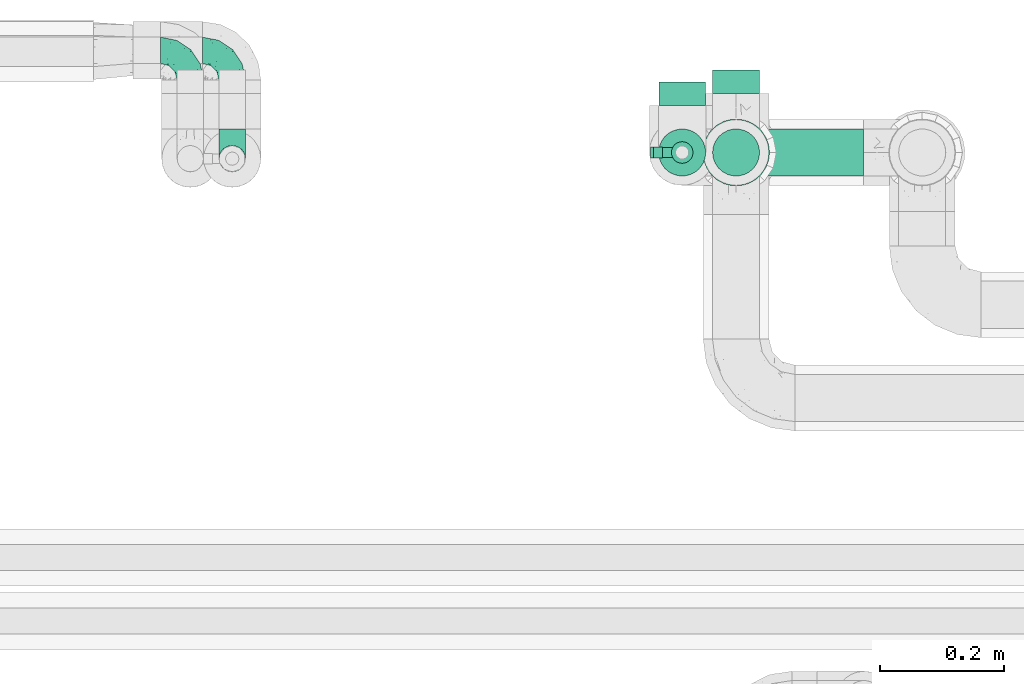
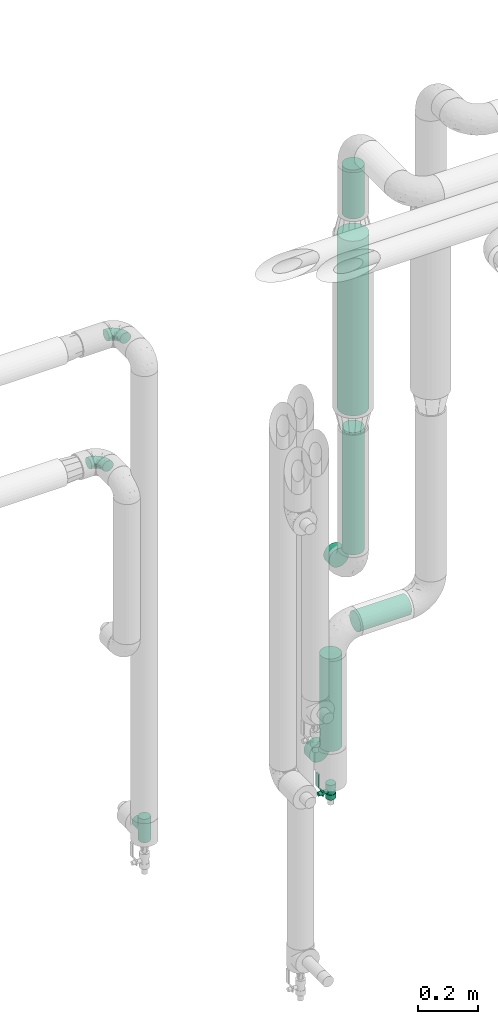
# One storey, part 641 of 827: 5 flow fittings, 5 flow segments, 1 flow controller.
"""IFC2X3 building model written with IfcOpenShell, lengths in millimetres."""

from ifc_helpers import new_model, entity, si_unit, converted_unit, derived_unit, direction, frame, origin, origin_2d_with_axis, place, context, subcontext, project, spatial, polyline, circle, outline, extrude, faceted_brep, source, transform, mapped, material, material_list, type_object, type_shapes, element, save


model = new_model("IFC2X3")

# Units and contexts
model_context = context("Model", 3, precision=0.01, world=origin(), true_north=direction((6.12303176911189e-17, 1.0)))
body_context = subcontext(model_context, "Body", "Model", "MODEL_VIEW")
ifc_project = project(units=[si_unit("LENGTHUNIT", "METRE", prefix="MILLI"), si_unit("AREAUNIT", "SQUARE_METRE"), si_unit("VOLUMEUNIT", "CUBIC_METRE"), converted_unit("PLANEANGLEUNIT", "DEGREE", entity("IfcRatioMeasure", 0.0174532925199433), si_unit("PLANEANGLEUNIT", "RADIAN"), dimensions=[0, 0, 0, 0, 0, 0, 0]), si_unit("MASSUNIT", "GRAM", prefix="KILO"), derived_unit("MASSDENSITYUNIT", [(si_unit("MASSUNIT", "GRAM", prefix="KILO"), 1), (si_unit("LENGTHUNIT", "METRE"), -3)]), derived_unit("MOMENTOFINERTIAUNIT", [(si_unit("LENGTHUNIT", "METRE"), 4)]), si_unit("TIMEUNIT", "SECOND"), si_unit("FREQUENCYUNIT", "HERTZ"), si_unit("THERMODYNAMICTEMPERATUREUNIT", "DEGREE_CELSIUS"), derived_unit("THERMALTRANSMITTANCEUNIT", [(si_unit("MASSUNIT", "GRAM", prefix="KILO"), 1), (si_unit("THERMODYNAMICTEMPERATUREUNIT", "KELVIN"), -1), (si_unit("TIMEUNIT", "SECOND"), -3)]), derived_unit("VOLUMETRICFLOWRATEUNIT", [(si_unit("LENGTHUNIT", "METRE"), 3), (si_unit("TIMEUNIT", "SECOND"), -1)]), derived_unit("MASSFLOWRATEUNIT", [(si_unit("MASSUNIT", "GRAM", prefix="KILO"), 1), (si_unit("TIMEUNIT", "SECOND"), -1)]), derived_unit("ROTATIONALFREQUENCYUNIT", [(si_unit("TIMEUNIT", "SECOND"), -1)]), si_unit("ELECTRICCURRENTUNIT", "AMPERE"), si_unit("ELECTRICVOLTAGEUNIT", "VOLT"), si_unit("POWERUNIT", "WATT"), si_unit("FORCEUNIT", "NEWTON", prefix="KILO"), si_unit("ILLUMINANCEUNIT", "LUX"), si_unit("LUMINOUSFLUXUNIT", "LUMEN"), si_unit("LUMINOUSINTENSITYUNIT", "CANDELA"), derived_unit("USERDEFINED", [(si_unit("MASSUNIT", "GRAM", prefix="KILO"), -1), (si_unit("LENGTHUNIT", "METRE"), -2), (si_unit("TIMEUNIT", "SECOND"), 3), (si_unit("LUMINOUSFLUXUNIT", "LUMEN"), 1)]), derived_unit("LINEARVELOCITYUNIT", [(si_unit("LENGTHUNIT", "METRE"), 1), (si_unit("TIMEUNIT", "SECOND"), -1)]), si_unit("PRESSUREUNIT", "PASCAL"), derived_unit("USERDEFINED", [(si_unit("LENGTHUNIT", "METRE"), -2), (si_unit("MASSUNIT", "GRAM", prefix="KILO"), 1), (si_unit("TIMEUNIT", "SECOND"), -2)]), derived_unit("LINEARFORCEUNIT", [(si_unit("MASSUNIT", "GRAM", prefix="KILO"), 1), (si_unit("LENGTHUNIT", "METRE"), 1), (si_unit("TIMEUNIT", "SECOND"), -2), (si_unit("LENGTHUNIT", "METRE"), -1)]), derived_unit("PLANARFORCEUNIT", [(si_unit("MASSUNIT", "GRAM", prefix="KILO"), 1), (si_unit("LENGTHUNIT", "METRE"), 1), (si_unit("TIMEUNIT", "SECOND"), -2), (si_unit("LENGTHUNIT", "METRE"), -2)])], contexts=[model_context])

# Site, building, storey
site_placement = place(None, origin())
site = spatial("IfcSite", under=ifc_project, at=site_placement, CompositionType="ELEMENT")
building_placement = place(site_placement, origin())
building = spatial("IfcBuilding", under=site, at=building_placement, CompositionType="ELEMENT")
storey_placement = place(building_placement, frame((0.0, 0.0, 28200.0)))
storey = spatial("IfcBuildingStorey", under=building, at=storey_placement, Name="08", CompositionType="ELEMENT", Elevation=28200.0)

# Flow segments
pipe_segment_type = type_object("IfcPipeSegmentType", PredefinedType="NOTDEFINED")
flow_segment_1_placement = place(storey_placement, frame((31328.81, 19313.84, 451.0)))
element("IfcFlowSegment", 1, at=flow_segment_1_placement, inside=storey, type_object=pipe_segment_type, context=body_context, shape_type="SweptSolid", body=[
    extrude(circle(Radius=38.0, at=origin_2d_with_axis()), frame((39.6, 39.6, 0.0), z_axis=(0.0, 0.0, 1.0), x_axis=(-1.0, 0.0, 0.0)), (0.0, 0.0, 1.0), 379.261639999987),
])
flow_segment_2_placement = place(storey_placement, frame((31463.41, 19313.84, 885.67)))
element("IfcFlowSegment", 2, at=flow_segment_2_placement, inside=storey, type_object=pipe_segment_type, context=body_context, shape_type="SweptSolid", body=[
    extrude(circle(Radius=38.0, at=origin_2d_with_axis()), frame((0.0, 39.6, 39.6), z_axis=(1.0, 0.0, 0.0), x_axis=(0.0, -1.0, 0.0)), (0.0, 0.0, 1.0), 197.500000000011),
])
flow_segment_3_placement = place(storey_placement, frame((31399.81, 19297.84, 1805.45)))
element("IfcFlowSegment", 3, at=flow_segment_3_placement, inside=storey, type_object=pipe_segment_type, context=body_context, shape_type="SweptSolid", body=[
    extrude(circle(Radius=54.0, at=origin_2d_with_axis()), frame((55.6, 55.6, 0.0)), (0.0, 0.0, 1.0), 714.55174000002),
])
flow_segment_4_placement = place(storey_placement, frame((31415.81, 19313.84, 1225.45)))
element("IfcFlowSegment", 4, at=flow_segment_4_placement, inside=storey, type_object=pipe_segment_type, context=body_context, shape_type="SweptSolid", body=[
    extrude(circle(Radius=38.0, at=origin_2d_with_axis()), frame((39.6, 39.6, 0.0), z_axis=(0.0, 0.0, 1.0), x_axis=(-1.0, 0.0, 0.0)), (0.0, 0.0, 1.0), 500.000000000008),
])
flow_segment_5_placement = place(storey_placement, frame((31415.81, 19313.84, 2600.0)))
element("IfcFlowSegment", 5, at=flow_segment_5_placement, inside=storey, type_object=pipe_segment_type, context=body_context, shape_type="SweptSolid", body=[
    extrude(circle(Radius=38.0, at=origin_2d_with_axis()), frame((39.6, 39.6, 0.0), z_axis=(0.0, 0.0, 1.0), x_axis=(-1.0, 0.0, 0.0)), (0.0, 0.0, 1.0), 200.080617222013),
])

# Flow controller
ifc_material = material()
ifc_material_list = material_list([ifc_material, ifc_material, ifc_material, ifc_material, ifc_material])
valve_type = type_object("IfcValveType", PredefinedType="NOTDEFINED", material=ifc_material_list)
shared_shape_1 = source(origin(), body_context, "Body", "SweptSolid", [
    extrude(circle(Radius=17.5, at=origin_2d_with_axis()), frame((-30.5, 0.0, 0.0), z_axis=(1.0, 0.0, 0.0), x_axis=(0.0, 1.0, 0.0)), (0.0, 0.0, 1.0), 20.3333333333333),
    extrude(circle(Radius=16.0, at=origin_2d_with_axis()), frame((-10.17, 0.0, 0.0), z_axis=(1.0, 0.0, 0.0), x_axis=(0.0, 1.0, 0.0)), (0.0, 0.0, 1.0), 20.3333333333333),
    extrude(circle(Radius=17.5, at=origin_2d_with_axis()), frame((10.17, 0.0, 0.0), z_axis=(1.0, 0.0, 0.0), x_axis=(0.0, 1.0, 0.0)), (0.0, 0.0, 1.0), 20.3333333333333),
    extrude(outline(polyline([(-38.75, -5.0), (-38.75, -10.0), (-17.92, -10.0), (2.08, 5.0), (56.25, 5.0), (56.25, 10.0), (0.42, 10.0), (-19.58, -5.0), (-38.75, -5.0)])), frame((28.75, -8.75, 41.5), z_axis=(0.0, -1.0, 0.0), x_axis=(1.0, 0.0, 0.0)), (0.0, 0.0, -1.0), 17.5),
    extrude(circle(Radius=8.0, at=origin_2d_with_axis()), origin(), (0.0, 0.0, 1.0), 49.0),
])
type_shapes(valve_type, [shared_shape_1])
flow_controller_placement = place(storey_placement, frame((31368.41, 19353.43, 268.5), z_axis=(-1.0, 0.0, 0.0), x_axis=(0.0, 0.0, 1.0)))
element("IfcFlowController", 6, at=flow_controller_placement, inside=storey, type_object=valve_type, material=ifc_material, context=body_context, shape_type="MappedRepresentation", body=[
    mapped(shared_shape_1, transform((0.0, 0.0, 0.0), scale=1.0)),
])

# Flow fittings
pipe_fitting_type_1 = type_object("IfcPipeFittingType", Name="ADSK_1", PredefinedType="NOTDEFINED", material=ifc_material)
shared_shape_2 = source(origin(), body_context, "Body", "SweptSolid", [
    extrude(circle(Radius=38.05, at=origin_2d_with_axis()), frame((0.0, 0.0, 0.0), z_axis=(1.0, 0.0, 0.0), x_axis=(0.0, 1.0, 0.0)), (0.0, 0.0, 1.0), 38.0000000000003),
])
type_shapes(pipe_fitting_type_1, [shared_shape_2])
for number, where, z_axis, x_axis, name in (
    (7, (31455.41, 19448.43, 1130.45), (1.0, 0.0, 0.0), (0.0, 1.0, 0.0), "ADSK_1"),
    (8, (31368.41, 19429.43, 375.0), (-1.0, 0.0, 0.0), (0.0, 1.0, 0.0), "ADSK_1"),
):
    element("IfcFlowFitting", number, at=place(storey_placement, frame(where, z_axis=z_axis, x_axis=x_axis)), inside=storey, type_object=pipe_fitting_type_1, material=ifc_material, Name=name, ObjectType="ADSK_1", context=body_context, shape_type="MappedRepresentation", body=[
        mapped(shared_shape_2, transform((0.0, 0.0, 0.0), scale=1.0)),
    ])
pipe_fitting_type_2 = type_object("IfcPipeFittingType", Name="ADSK_1", PredefinedType="NOTDEFINED", material=ifc_material)
shared_shape_3 = source(origin(), body_context, "Body", "Brep", [
    faceted_brep([(-48.0, 10.6, -18.36), (-48.0, 5.49, -20.48), (-48.0, 0.0, -21.2), (-48.0, -5.49, -20.48), (-48.0, -10.6, -18.36), (-48.0, -14.99, -14.99), (-48.0, -18.36, -10.6), (-48.0, -20.48, -5.49), (-48.0, -21.2, 0.0), (-48.0, -20.48, 5.49), (-48.0, -18.36, 10.6), (-48.0, -14.99, 14.99), (-48.0, -10.6, 18.36), (-48.0, -5.49, 20.48), (-48.0, 0.0, 21.2), (-48.0, 5.49, 20.48), (-48.0, 10.6, 18.36), (-48.0, 14.99, 14.99), (-48.0, 18.36, 10.6), (-48.0, 20.48, 5.49), (-48.0, 21.2, 0.0), (-48.0, 20.48, -5.49), (-48.0, 18.36, -10.6), (-48.0, 14.99, -14.99), (0.0, 48.0, -21.2), (-5.49, 48.0, -20.48), (-10.6, 48.0, -18.36), (-14.99, 48.0, -14.99), (-18.36, 48.0, -10.6), (-20.48, 48.0, -5.49), (-21.2, 48.0, 0.0), (-20.48, 48.0, 5.49), (-18.36, 48.0, 10.6), (-14.99, 48.0, 14.99), (-10.6, 48.0, 18.36), (-5.49, 48.0, 20.48), (0.0, 48.0, 21.2), (5.49, 48.0, 20.48), (10.6, 48.0, 18.36), (14.99, 48.0, 14.99), (18.36, 48.0, 10.6), (20.48, 48.0, 5.49), (21.2, 48.0, 0.0), (20.48, 48.0, -5.49), (18.36, 48.0, -10.6), (14.99, 48.0, -14.99), (10.6, 48.0, -18.36), (5.49, 48.0, -20.48), (-35.25, -16.22, 12.01), (-34.76, -18.57, 0.0), (-20.87, -12.37, 10.9), (-31.49, -11.78, 15.9), (-37.0, -2.58, 20.86), (-33.89, 3.62, 21.15), (-31.81, -18.14, 6.76), (-5.78, 5.78, 17.67), (-19.42, -4.1, 17.86), (-9.6, -3.39, 13.73), (-35.44, -7.73, 19.13), (11.78, 31.49, 15.9), (-5.93, -5.46, 6.95), (-18.45, -13.78, 5.46), (-10.29, -8.43, 0.0), (-24.6, 0.55, 20.62), (-37.28, 17.94, 13.81), (-33.38, 22.85, 9.59), (-41.46, 20.06, 8.75), (-29.51, 20.45, 15.16), (-15.04, 10.79, 21.13), (-7.08, 16.98, 20.93), (-8.39, 23.51, 21.15), (-40.86, 13.03, 17.26), (-8.05, 41.26, 19.83), (-3.21, 35.97, 21.14), (8.53, 19.66, 14.74), (4.1, 19.42, 17.86), (-37.72, 22.66, 4.78), (-37.07, 8.58, 19.98), (-13.0, 5.43, 19.97), (-3.78, 13.93, 19.7), (3.02, 8.69, 13.43), (-2.27, -0.05, 10.65), (6.22, 6.99, 7.09), (-22.25, 34.6, 9.45), (18.14, 31.81, 6.76), (16.22, 35.25, 12.01), (12.37, 20.87, 10.9), (7.73, 35.44, 19.13), (-21.52, -15.93, 0.0), (2.58, 37.0, 20.86), (18.57, 34.76, 0.0), (13.78, 18.45, 5.46), (15.93, 21.52, 0.0), (-20.03, -8.54, 14.9), (-28.6, 28.6, 5.16), (-24.79, 34.6, 0.0), (-34.6, 24.79, 0.0), (-22.81, 37.41, 4.68), (-23.36, 26.33, 14.79), (-13.68, 37.05, 17.49), (-17.72, 38.12, 13.73), (-26.25, 27.3, 11.24), (-9.71, 32.34, 20.14), (-17.26, 25.6, 18.71), (-26.33, 9.99, 20.77), (-24.06, 6.05, 21.2), (-25.02, 15.46, 19.56), (-24.3, 20.72, 17.57), (-31.95, 15.23, 17.8), (-13.53, 24.7, 20.21), (-17.6, 17.6, 20.6), (-0.55, 24.6, 20.62), (-11.41, -7.48, 10.43), (0.93, -0.93, 0.0), (8.43, 10.29, 0.0), (-11.41, -7.48, -10.43), (-20.1, -8.84, -14.66), (-9.6, -3.39, -13.73), (7.73, 35.44, -19.13), (4.1, 19.42, -17.86), (-0.55, 24.6, -20.62), (-38.12, 17.72, -13.73), (-37.05, 13.68, -17.49), (-32.34, 9.71, -20.14), (-41.26, 8.05, -19.83), (-37.41, 22.81, -4.68), (-23.51, 8.39, -21.15), (-35.97, 3.21, -21.14), (-28.6, 28.6, -5.16), (-31.81, -18.14, -6.76), (-18.45, -13.78, -5.46), (-25.6, 17.26, -18.71), (-19.42, -4.1, -17.86), (-17.94, 37.28, -13.81), (-22.85, 33.38, -9.59), (-20.06, 41.46, -8.75), (-31.49, -11.78, -15.9), (-35.25, -16.22, -12.01), (8.53, 19.66, -14.74), (11.78, 31.49, -15.9), (-9.99, 26.33, -20.77), (-6.05, 24.06, -21.2), (-10.79, 15.04, -21.13), (-37.0, -2.58, -20.86), (-16.98, 7.08, -20.93), (-5.43, 13.0, -19.97), (-13.93, 3.78, -19.7), (-20.87, -12.37, -10.9), (-26.33, 23.36, -14.79), (-22.66, 37.72, -4.78), (13.78, 18.45, -5.46), (18.14, 31.81, -6.76), (-15.46, 25.02, -19.56), (-20.72, 24.3, -17.57), (16.22, 35.25, -12.01), (-13.03, 40.86, -17.26), (-8.58, 37.07, -19.98), (2.58, 37.0, -20.86), (-3.62, 33.89, -21.15), (-34.6, 22.25, -9.45), (6.22, 6.99, -7.09), (-20.45, 29.51, -15.16), (-35.44, -7.73, -19.13), (12.37, 20.87, -10.9), (-27.3, 26.25, -11.24), (-15.23, 31.95, -17.8), (-24.7, 13.53, -20.21), (-24.6, 0.55, -20.62), (-5.78, 5.78, -17.67), (-17.6, 17.6, -20.6), (3.02, 8.69, -13.43), (-5.93, -5.46, -6.95), (-2.27, -0.05, -10.65)], [[[0, 1, 2, 3, 4, 5, 6, 7, 8, 9, 10, 11, 12, 13, 14, 15, 16, 17, 18, 19, 20, 21, 22, 23]], [[24, 25, 26, 27, 28, 29, 30, 31, 32, 33, 34, 35, 36, 37, 38, 39, 40, 41, 42, 43, 44, 45, 46, 47]], [[10, 48, 11]], [[9, 8, 49]], [[48, 50, 51]], [[14, 52, 53]], [[10, 54, 48]], [[9, 54, 10]], [[55, 56, 57]], [[51, 12, 11]], [[51, 58, 12]], [[59, 39, 38]], [[60, 61, 62]], [[58, 56, 63]], [[64, 65, 66]], [[67, 65, 64]], [[68, 69, 70]], [[16, 71, 17]], [[13, 52, 14]], [[35, 72, 73]], [[14, 53, 15]], [[17, 64, 18]], [[74, 59, 75]], [[20, 19, 76]], [[66, 19, 18]], [[77, 15, 53]], [[15, 77, 16]], [[69, 78, 79]], [[80, 81, 82]], [[32, 31, 83]], [[84, 85, 86]], [[59, 87, 75]], [[61, 54, 88]], [[36, 89, 37]], [[84, 41, 40]], [[36, 35, 73]], [[90, 41, 84]], [[40, 39, 85]], [[12, 58, 13]], [[85, 84, 40]], [[91, 84, 86]], [[84, 92, 90]], [[87, 38, 37]], [[93, 56, 51]], [[65, 94, 76]], [[94, 95, 96]], [[84, 91, 92]], [[95, 97, 30]], [[98, 99, 100]], [[76, 94, 96]], [[101, 98, 83]], [[100, 99, 33]], [[102, 70, 73]], [[103, 102, 99]], [[94, 97, 95]], [[72, 99, 102]], [[72, 35, 34]], [[34, 33, 99]], [[9, 49, 54]], [[87, 59, 38]], [[104, 105, 68]], [[106, 103, 107]], [[106, 77, 104]], [[71, 64, 17]], [[108, 107, 67]], [[33, 32, 100]], [[109, 103, 110]], [[102, 109, 70]], [[89, 73, 111]], [[50, 48, 54]], [[51, 11, 48]], [[56, 58, 51]], [[88, 54, 49]], [[52, 58, 63]], [[50, 112, 93]], [[56, 55, 78]], [[39, 59, 85]], [[86, 85, 59]], [[89, 87, 37]], [[42, 41, 90]], [[111, 79, 75]], [[111, 75, 87]], [[75, 55, 80]], [[104, 77, 53]], [[71, 77, 108]], [[32, 83, 100]], [[98, 100, 83]], [[99, 98, 103]], [[106, 107, 108]], [[68, 70, 110]], [[111, 73, 70]], [[68, 110, 104]], [[68, 63, 78]], [[57, 93, 112]], [[80, 55, 57]], [[61, 50, 54]], [[80, 82, 86]], [[81, 57, 112]], [[74, 86, 59]], [[60, 113, 82]], [[82, 114, 91]], [[101, 94, 65]], [[97, 94, 83]], [[73, 89, 36]], [[87, 89, 111]], [[58, 52, 13]], [[53, 52, 63]], [[104, 53, 105]], [[106, 104, 110]], [[20, 76, 96]], [[76, 19, 66]], [[103, 106, 110]], [[77, 106, 108]], [[103, 98, 107]], [[67, 107, 98]], [[67, 98, 101]], [[108, 67, 64]], [[53, 63, 105]], [[63, 68, 105]], [[83, 31, 97]], [[30, 97, 31]], [[62, 113, 60]], [[112, 61, 60]], [[61, 88, 62]], [[86, 82, 91]], [[56, 78, 63]], [[114, 82, 113]], [[114, 92, 91]], [[79, 78, 55]], [[75, 79, 55]], [[69, 79, 111]], [[70, 69, 111]], [[78, 69, 68]], [[77, 71, 16]], [[64, 71, 108]], [[64, 66, 18]], [[76, 66, 65]], [[99, 72, 34]], [[73, 72, 102]], [[94, 101, 83]], [[67, 101, 65]], [[75, 80, 74]], [[80, 86, 74]], [[70, 109, 110]], [[102, 103, 109]], [[50, 93, 51]], [[57, 56, 93]], [[61, 112, 50]], [[81, 112, 60]], [[82, 81, 60]], [[80, 57, 81]], [[115, 116, 117]], [[118, 119, 120]], [[121, 122, 23]], [[123, 124, 122]], [[96, 125, 20]], [[123, 126, 127]], [[128, 96, 95]], [[129, 130, 88]], [[123, 122, 131]], [[116, 132, 117]], [[133, 134, 135]], [[0, 124, 1]], [[5, 136, 137]], [[138, 119, 139]], [[129, 88, 49]], [[140, 141, 142]], [[6, 5, 137]], [[46, 118, 47]], [[143, 3, 2]], [[144, 145, 146]], [[6, 129, 7]], [[129, 137, 147]], [[127, 2, 1]], [[148, 122, 121]], [[128, 125, 96]], [[134, 128, 149]], [[95, 149, 128]], [[150, 151, 92]], [[30, 29, 149]], [[152, 131, 153]], [[27, 133, 28]], [[154, 45, 44]], [[136, 5, 4]], [[27, 26, 155]], [[156, 26, 25]], [[24, 157, 158]], [[24, 47, 157]], [[22, 21, 159]], [[160, 150, 114]], [[134, 133, 161]], [[142, 144, 126]], [[46, 139, 118]], [[162, 136, 4]], [[156, 25, 158]], [[1, 124, 127]], [[115, 147, 116]], [[45, 154, 139]], [[139, 46, 45]], [[154, 163, 139]], [[162, 4, 3]], [[42, 90, 43]], [[130, 129, 147]], [[49, 7, 129]], [[43, 151, 44]], [[0, 23, 122]], [[24, 158, 25]], [[136, 162, 132]], [[135, 29, 28]], [[43, 90, 151]], [[164, 148, 159]], [[152, 156, 140]], [[155, 133, 27]], [[165, 153, 161]], [[23, 22, 121]], [[123, 131, 166]], [[123, 166, 126]], [[143, 127, 167]], [[147, 137, 136]], [[8, 7, 49]], [[129, 6, 137]], [[143, 162, 3]], [[167, 146, 132]], [[167, 132, 162]], [[132, 168, 117]], [[44, 151, 154]], [[92, 151, 90]], [[163, 154, 151]], [[119, 118, 139]], [[157, 118, 120]], [[138, 139, 163]], [[119, 168, 145]], [[140, 156, 158]], [[155, 156, 165]], [[22, 159, 121]], [[148, 121, 159]], [[122, 148, 131]], [[152, 153, 165]], [[142, 126, 169]], [[167, 127, 126]], [[142, 169, 140]], [[142, 120, 145]], [[168, 170, 117]], [[160, 171, 172]], [[115, 172, 171]], [[171, 62, 130]], [[119, 170, 168]], [[170, 163, 160]], [[150, 163, 151]], [[113, 171, 160]], [[164, 128, 134]], [[125, 128, 159]], [[127, 143, 2]], [[162, 143, 167]], [[118, 157, 47]], [[158, 157, 120]], [[140, 158, 141]], [[152, 140, 169]], [[30, 149, 95]], [[149, 29, 135]], [[131, 152, 169]], [[156, 152, 165]], [[131, 148, 153]], [[161, 153, 148]], [[161, 148, 164]], [[165, 161, 133]], [[158, 120, 141]], [[120, 142, 141]], [[159, 21, 125]], [[20, 125, 21]], [[115, 130, 147]], [[114, 113, 160]], [[62, 171, 113]], [[62, 88, 130]], [[160, 163, 150]], [[150, 92, 114]], [[119, 145, 120]], [[146, 145, 168]], [[132, 146, 168]], [[144, 146, 167]], [[126, 144, 167]], [[145, 144, 142]], [[156, 155, 26]], [[133, 155, 165]], [[133, 135, 28]], [[149, 135, 134]], [[122, 124, 0]], [[127, 124, 123]], [[128, 164, 159]], [[161, 164, 134]], [[163, 170, 138]], [[170, 119, 138]], [[131, 169, 166]], [[126, 166, 169]], [[147, 136, 116]], [[132, 116, 136]], [[172, 115, 117]], [[130, 115, 171]], [[117, 170, 172]], [[160, 172, 170]]]),
])
type_shapes(pipe_fitting_type_2, [shared_shape_3])
for number, where, z_axis, x_axis, name in (
    (9, (30642.2, 19518.43, 2300.0), (0.0, 0.0, 1.0), (0.0, 1.0, 0.0), "ADSK_1"),
    (10, (30574.59, 19518.34, 1800.0), (0.0, 0.0, 1.0), (0.0, 1.0, 0.0), "ADSK_1"),
):
    element("IfcFlowFitting", number, at=place(storey_placement, frame(where, z_axis=z_axis, x_axis=x_axis)), inside=storey, type_object=pipe_fitting_type_2, material=ifc_material, Name=name, ObjectType="ADSK_1", context=body_context, shape_type="MappedRepresentation", body=[
        mapped(shared_shape_3, transform((0.0, 0.0, 0.0), scale=1.0)),
    ])
pipe_fitting_type_3 = type_object("IfcPipeFittingType", Name="ADSK_1", PredefinedType="NOTDEFINED", material=ifc_material)
shared_shape_4 = source(origin(), body_context, "Body", "Brep", [
    faceted_brep([(-48.0, 10.6, -18.36), (-48.0, 5.49, -20.48), (-48.0, 0.0, -21.2), (-48.0, -5.49, -20.48), (-48.0, -10.6, -18.36), (-48.0, -14.99, -14.99), (-48.0, -18.36, -10.6), (-48.0, -20.48, -5.49), (-48.0, -21.2, 0.0), (-48.0, -20.48, 5.49), (-48.0, -18.36, 10.6), (-48.0, -14.99, 14.99), (-48.0, -10.6, 18.36), (-48.0, -5.49, 20.48), (-48.0, 0.0, 21.2), (-48.0, 5.49, 20.48), (-48.0, 10.6, 18.36), (-48.0, 14.99, 14.99), (-48.0, 18.36, 10.6), (-48.0, 20.48, 5.49), (-48.0, 21.2, 0.0), (-48.0, 20.48, -5.49), (-48.0, 18.36, -10.6), (-48.0, 14.99, -14.99), (48.0, 0.0, -21.2), (48.0, 5.49, -20.48), (48.0, 10.6, -18.36), (48.0, 14.99, -14.99), (48.0, 18.36, -10.6), (48.0, 20.48, -5.49), (48.0, 21.2, 0.0), (48.0, 20.48, 5.49), (48.0, 18.36, 10.6), (48.0, 14.99, 14.99), (48.0, 10.6, 18.36), (48.0, 5.49, 20.48), (48.0, 0.0, 21.2), (48.0, -5.49, 20.48), (48.0, -10.6, 18.36), (48.0, -14.99, 14.99), (48.0, -18.36, 10.6), (48.0, -20.48, 5.49), (48.0, -21.2, 0.0), (48.0, -20.48, -5.49), (48.0, -18.36, -10.6), (48.0, -14.99, -14.99), (48.0, -10.6, -18.36), (48.0, -5.49, -20.48), (20.43, -20.43, 5.66), (21.2, -21.2, 0.0), (-21.2, -21.2, 0.0), (18.35, -18.35, 10.62), (11.88, -11.88, 17.56), (15.38, -15.38, 14.59), (-20.43, -20.43, 5.66), (-18.35, -18.35, 10.62), (-15.38, -15.38, 14.59), (-11.88, -11.88, 17.56), (-8.06, -8.06, 19.61), (8.06, -8.06, 19.61), (4.07, -4.07, 20.81), (0.0, 0.0, 21.2), (-4.07, -4.07, 20.81), (4.07, -4.07, -20.81), (0.0, 0.0, -21.2), (-4.07, -4.07, -20.81), (-8.06, -8.06, -19.61), (8.06, -8.06, -19.61), (11.88, -11.88, -17.56), (15.38, -15.38, -14.59), (18.35, -18.35, -10.62), (20.43, -20.43, -5.66), (-11.88, -11.88, -17.56), (-15.38, -15.38, -14.59), (-20.43, -20.43, -5.66), (-18.35, -18.35, -10.62), (0.0, -48.0, -21.2), (5.49, -48.0, -20.48), (10.6, -48.0, -18.36), (14.99, -48.0, -14.99), (18.36, -48.0, -10.6), (20.48, -48.0, -5.49), (21.2, -48.0, 0.0), (20.48, -48.0, 5.49), (18.36, -48.0, 10.6), (14.99, -48.0, 14.99), (10.6, -48.0, 18.36), (5.49, -48.0, 20.48), (0.0, -48.0, 21.2), (-5.49, -48.0, 20.48), (-10.6, -48.0, 18.36), (-14.99, -48.0, 14.99), (-18.36, -48.0, 10.6), (-20.48, -48.0, 5.49), (-21.2, -48.0, 0.0), (-20.48, -48.0, -5.49), (-18.36, -48.0, -10.6), (-14.99, -48.0, -14.99), (-10.6, -48.0, -18.36), (-5.49, -48.0, -20.48)], [[[0, 1, 2, 3, 4, 5, 6, 7, 8, 9, 10, 11, 12, 13, 14, 15, 16, 17, 18, 19, 20, 21, 22, 23]], [[24, 25, 26, 27, 28, 29, 30, 31, 32, 33, 34, 35, 36, 37, 38, 39, 40, 41, 42, 43, 44, 45, 46, 47]], [[41, 40, 48]], [[42, 41, 49]], [[50, 9, 8]], [[49, 41, 48]], [[40, 51, 48]], [[39, 38, 52]], [[51, 40, 53]], [[52, 53, 39]], [[53, 40, 39]], [[50, 54, 9]], [[9, 54, 10]], [[54, 55, 10]], [[56, 57, 11]], [[11, 10, 56]], [[11, 57, 12]], [[56, 10, 55]], [[12, 57, 58]], [[52, 38, 59]], [[60, 36, 61]], [[62, 61, 14]], [[59, 37, 60]], [[37, 59, 38]], [[60, 37, 36]], [[61, 36, 35, 15, 14]], [[32, 31, 19, 18]], [[17, 16, 34, 33]], [[18, 17, 33, 32]], [[35, 34, 16, 15]], [[20, 19, 31, 30]], [[62, 13, 58]], [[13, 62, 14]], [[58, 13, 12]], [[27, 23, 22, 28]], [[22, 21, 29, 28]], [[0, 23, 27, 26]], [[20, 30, 29, 21]], [[24, 47, 63]], [[24, 64, 2, 1, 25]], [[64, 24, 63]], [[2, 64, 65]], [[26, 25, 1, 0]], [[65, 66, 3]], [[2, 65, 3]], [[66, 4, 3]], [[63, 47, 67]], [[46, 45, 68]], [[69, 68, 45]], [[44, 70, 69]], [[69, 45, 44]], [[46, 68, 67]], [[43, 42, 49]], [[7, 50, 8]], [[43, 71, 44]], [[71, 43, 49]], [[44, 71, 70]], [[72, 4, 66]], [[72, 5, 4]], [[5, 72, 73]], [[5, 73, 6]], [[74, 50, 7]], [[75, 74, 6]], [[74, 7, 6]], [[75, 6, 73]], [[46, 67, 47]], [[76, 77, 78, 79, 80, 81, 82, 83, 84, 85, 86, 87, 88, 89, 90, 91, 92, 93, 94, 95, 96, 97, 98, 99]], [[50, 94, 93]], [[54, 50, 93]], [[91, 90, 57]], [[56, 92, 91]], [[54, 93, 92]], [[58, 90, 89]], [[55, 54, 92]], [[56, 55, 92]], [[58, 57, 90]], [[88, 61, 62]], [[58, 89, 62]], [[56, 91, 57]], [[62, 89, 88]], [[60, 88, 87]], [[86, 59, 87]], [[84, 83, 48]], [[53, 85, 84]], [[52, 86, 85]], [[49, 83, 82]], [[59, 60, 87]], [[52, 59, 86]], [[49, 48, 83]], [[51, 53, 84]], [[48, 51, 84]], [[52, 85, 53]], [[88, 60, 61]], [[82, 81, 49]], [[71, 49, 81]], [[69, 80, 79]], [[79, 78, 68]], [[71, 81, 80]], [[67, 78, 77]], [[70, 71, 80]], [[69, 70, 80]], [[67, 68, 78]], [[76, 64, 63]], [[67, 77, 63]], [[69, 79, 68]], [[63, 77, 76]], [[65, 76, 99]], [[98, 66, 99]], [[96, 95, 74]], [[73, 97, 96]], [[72, 98, 97]], [[50, 95, 94]], [[66, 65, 99]], [[72, 66, 98]], [[50, 74, 95]], [[75, 73, 96]], [[74, 75, 96]], [[72, 97, 73]], [[76, 65, 64]]]),
])
type_shapes(pipe_fitting_type_3, [shared_shape_4])
flow_fitting_placement = place(storey_placement, frame((30642.2, 19343.43, 375.0), z_axis=(-1.0, 0.0, 0.0), x_axis=(0.0, 0.0, -1.0)))
element("IfcFlowFitting", 11, at=flow_fitting_placement, inside=storey, type_object=pipe_fitting_type_3, material=ifc_material, Name="ADSK_1", ObjectType="ADSK_1", context=body_context, shape_type="MappedRepresentation", body=[
    mapped(shared_shape_4, transform((0.0, 0.0, 0.0), scale=1.0)),
])

save(model, "model.ifc")
